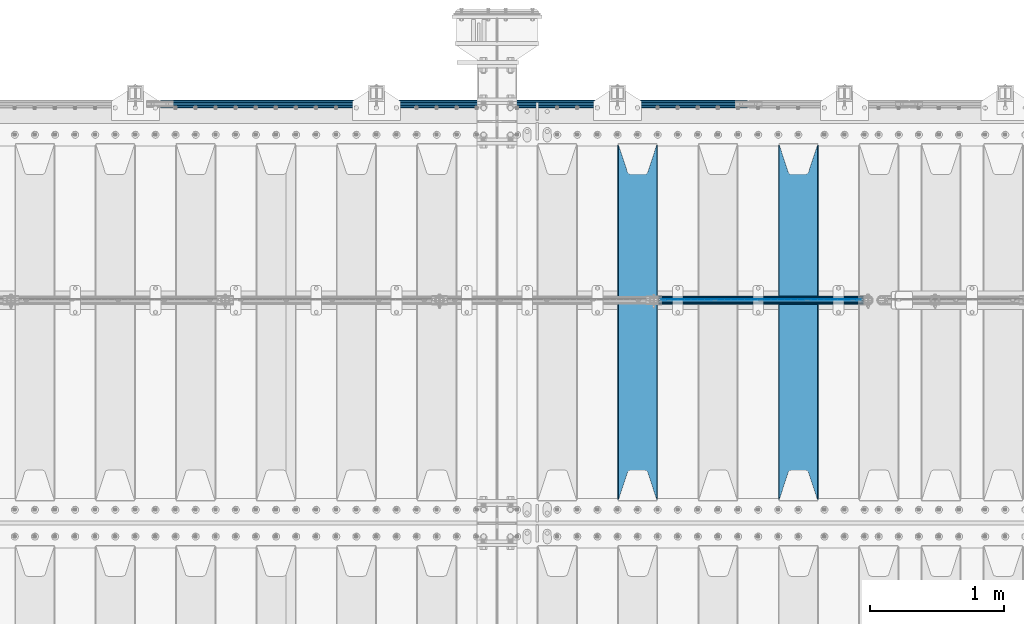
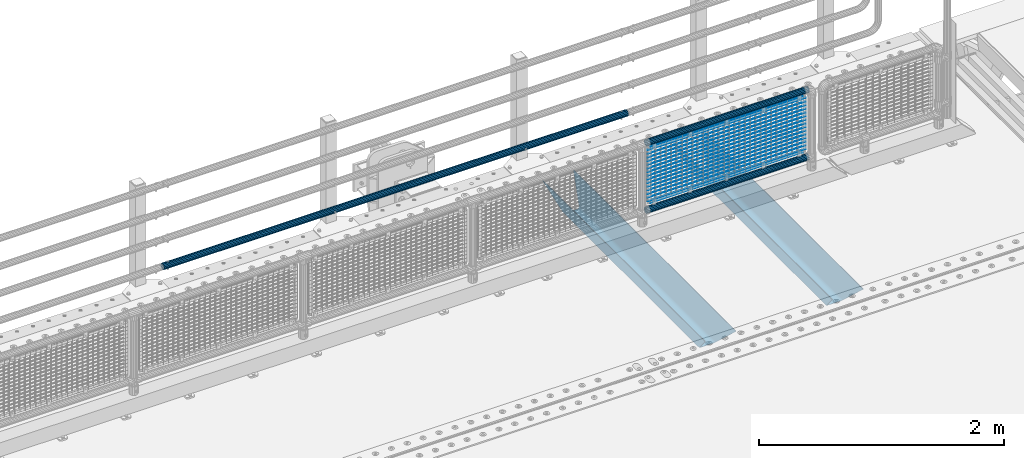
# One storey, part 107 of 208: 22 beams.
"""IFC2X3 building model written with IfcOpenShell, lengths in millimetres."""

from ifc_helpers import new_model, si_unit, frame, origin_with_axes, place, context, subcontext, project, spatial, faceted_brep, material, type_object, element, save


model = new_model("IFC2X3")

# Units and contexts
model_context = context("Model", 3, precision=1e-05, world=origin_with_axes())
body_context = subcontext(model_context, "Body", "Model", "MODEL_VIEW")
ifc_project = project(units=[si_unit("LENGTHUNIT", "METRE", prefix="MILLI"), si_unit("AREAUNIT", "SQUARE_METRE"), si_unit("VOLUMEUNIT", "CUBIC_METRE"), si_unit("MASSUNIT", "GRAM", prefix="KILO"), si_unit("TIMEUNIT", "SECOND"), si_unit("PLANEANGLEUNIT", "RADIAN"), si_unit("SOLIDANGLEUNIT", "STERADIAN"), si_unit("THERMODYNAMICTEMPERATUREUNIT", "DEGREE_CELSIUS"), si_unit("LUMINOUSINTENSITYUNIT", "LUMEN")], contexts=[model_context])

# Site, building, storey
site_placement = place(None, origin_with_axes())
site = spatial("IfcSite", under=ifc_project, at=site_placement, CompositionType="ELEMENT")
building_placement = place(site_placement, origin_with_axes())
building = spatial("IfcBuilding", under=site, at=building_placement, Name="Standard", CompositionType="ELEMENT")
storey_placement = place(building_placement, origin_with_axes())
storey = spatial("IfcBuildingStorey", under=building, at=storey_placement, Name="Undefined", CompositionType="ELEMENT", Elevation=0.0)

# Beams
ifc_material_1 = material(Name="STEEL/S355N")
beam_type_1 = type_object("IfcBeamType", PredefinedType="NOTDEFINED")
beam_1_placement = place(storey_placement, frame((-27950.0, 3175.0, -115.0), z_axis=(0.0, 0.0, 1.0), x_axis=(0.0, 1.0, 0.0)))
element("IfcBeam", 1, at=beam_1_placement, inside=storey, type_object=beam_type_1, material=ifc_material_1, context=body_context, shape_type="Brep", body=[
    faceted_brep([(0.0, 150.0, 115.0), (0.0, 143.689999999999, 115.0), (2650.00000000297, 143.689999999999, 115.0), (2650.00000000297, 150.0, 115.0), (2650.00000000297, 142.059565218402, 110.0000000031), (2650.00000000297, 148.369565218403, 110.0000000031), (2441.90079219208, -80.1103600731112, -98.0992078077845), (2437.7588105432, -77.5672621345584, -102.241189456673), (2434.06523489746, -74.4080125315522, -105.934765102404), (2430.91086095089, -70.710272125576, -109.089139048974), (2428.37322971128, -66.5649389910068, -111.626770288588), (2426.51472138055, -62.0739139532889, -113.485278619323), (2425.38102192091, -57.3475956567672, -114.618978078955), (2424.99999999987, -52.5021667386536, -115.0), (2424.99999999987, 52.5021667386536, -115.0), (2425.38102192091, 57.3475956567672, -114.618978078955), (2426.51472138055, 62.0739139532889, -113.485278619323), (2428.37322971128, 66.5649389910068, -111.626770288588), (2430.91086095089, 70.710272125576, -109.089139048974), (2434.06523489746, 74.4080125315522, -105.934765102404), (2437.7588105432, 77.5672621345584, -102.241189456673), (2441.90079219208, 80.1103600731112, -98.0992078077846), (2446.38936140511, 81.9747917625791, -93.6106385947584), (2448.24948500409, 76.2713538057251, -91.7505149957729), (2444.62967112262, 74.76777986261, -95.3703288772456), (2441.28936334126, 72.7168944282894, -98.710636658607), (2438.31067330438, 70.1691124903846, -101.689326695487), (2435.76682334747, 67.1870637758839, -104.233176652398), (2433.72034654133, 63.8440531834895, -106.279653458539), (2432.22154950041, 60.222258798236, -107.778450499454), (2431.30727574265, 56.4107117849089, -108.692724257221), (2430.99999999987, 52.5031078186876, -109.0), (2430.99999999987, -52.5031078186876, -109.0), (2431.30727574265, -56.4107117849089, -108.692724257221), (2432.22154950041, -60.222258798236, -107.778450499454), (2433.72034654133, -63.8440531834895, -106.279653458539), (2435.76682334747, -67.1870637758839, -104.233176652398), (2438.31067330438, -70.1691124903846, -101.689326695487), (2441.28936334126, -72.7168944282894, -98.7106366586071), (2444.62967112262, -74.76777986261, -95.3703288772457), (2448.24948500409, -76.2713538057251, -91.7505149957729), (2650.00000000297, -142.059565218402, 110.0000000031), (2650.00000000297, -148.369565218403, 110.0000000031), (2446.38936140511, -81.9747917625791, -93.6106385947584), (2650.00000000297, -143.689999999999, 115.0), (2650.00000000297, -150.0, 115.0), (0.0, -143.689999999999, 115.0), (0.0, -150.0, 115.0), (0.0, -148.369565218261, 110.000000002663), (203.610638597421, -81.9747917625791, -93.6106385947584), (208.099207810448, -80.1103600731112, -98.0992078077845), (212.241189459336, -77.5672621345584, -102.241189456673), (215.934765105067, -74.4080125315522, -105.934765102404), (219.089139051637, -70.710272125576, -109.089139048974), (221.626770291251, -66.5649389910068, -111.626770288588), (223.485278621986, -62.0739139532889, -113.485278619323), (224.618978081618, -57.3475956567672, -114.618978078955), (225.000000002663, -52.5021667386536, -115.0), (225.000000002663, 52.5021667386536, -115.0), (224.618978081618, 57.3475956567672, -114.618978078955), (223.485278621986, 62.0739139532889, -113.485278619323), (221.626770291251, 66.5649389910068, -111.626770288588), (219.089139051637, 70.710272125576, -109.089139048974), (215.934765105067, 74.4080125315522, -105.934765102404), (212.241189459336, 77.5672621345584, -102.241189456673), (208.099207810448, 80.1103600731112, -98.0992078077846), (203.610638597421, 81.9747917625791, -93.6106385947584), (0.0, 148.369565218261, 110.000000002663), (0.0, 142.05956521826, 110.000000002663), (201.750514998436, 76.2713538057251, -91.7505149957729), (205.370328879908, 74.76777986261, -95.3703288772456), (208.71063666127, 72.7168944282894, -98.710636658607), (211.68932669815, 70.1691124903846, -101.689326695487), (214.233176655061, 67.1870637758839, -104.233176652398), (216.279653461202, 63.8440531834895, -106.279653458539), (217.778450502116, 60.222258798236, -107.778450499454), (218.692724259884, 56.4107117849089, -108.692724257221), (219.000000002663, 52.5031078186876, -109.0), (219.000000002663, -52.5031078186876, -109.0), (218.692724259884, -56.4107117849089, -108.692724257221), (217.778450502116, -60.222258798236, -107.778450499454), (216.279653461202, -63.8440531834895, -106.279653458539), (214.233176655061, -67.1870637758839, -104.233176652398), (211.68932669815, -70.1691124903846, -101.689326695487), (208.71063666127, -72.7168944282894, -98.7106366586071), (205.370328879908, -74.76777986261, -95.3703288772457), (201.750514998436, -76.2713538057251, -91.7505149957729), (0.0, -142.05956521826, 110.000000002663)], [[[0, 1, 2, 3]], [[3, 2, 4, 5]], [[6, 7, 8, 9, 10, 11, 12, 13, 14, 15, 16, 17, 18, 19, 20, 21, 22, 5, 4, 23, 24, 25, 26, 27, 28, 29, 30, 31, 32, 33, 34, 35, 36, 37, 38, 39, 40, 41, 42, 43]], [[44, 45, 42, 41]], [[46, 47, 45, 44]], [[43, 42, 45, 47, 48, 49]], [[6, 43, 49, 50]], [[7, 6, 50, 51]], [[8, 7, 51, 52]], [[9, 8, 52, 53]], [[10, 9, 53, 54]], [[11, 10, 54, 55]], [[12, 11, 55, 56]], [[13, 12, 56, 57]], [[14, 13, 57, 58]], [[15, 14, 58, 59]], [[16, 15, 59, 60]], [[17, 16, 60, 61]], [[18, 17, 61, 62]], [[19, 18, 62, 63]], [[20, 19, 63, 64]], [[21, 20, 64, 65]], [[22, 21, 65, 66]], [[0, 3, 5, 22, 66, 67]], [[1, 0, 67, 68]], [[23, 4, 2, 1, 68, 69]], [[24, 23, 69, 70]], [[25, 24, 70, 71]], [[26, 25, 71, 72]], [[27, 26, 72, 73]], [[28, 27, 73, 74]], [[29, 28, 74, 75]], [[30, 29, 75, 76]], [[31, 30, 76, 77]], [[32, 31, 77, 78]], [[33, 32, 78, 79]], [[34, 33, 79, 80]], [[35, 34, 80, 81]], [[36, 35, 81, 82]], [[37, 36, 82, 83]], [[38, 37, 83, 84]], [[39, 38, 84, 85]], [[40, 39, 85, 86]], [[46, 44, 41, 40, 86, 87]], [[47, 46, 87, 48]], [[86, 85, 84, 83, 82, 81, 80, 79, 78, 77, 76, 75, 74, 73, 72, 71, 70, 69, 68, 67, 66, 65, 64, 63, 62, 61, 60, 59, 58, 57, 56, 55, 54, 53, 52, 51, 50, 49, 48, 87]]]),
])
beam_2_placement = place(storey_placement, frame((-29150.0, 3175.0, -115.0), z_axis=(0.0, 0.0, 1.0), x_axis=(0.0, 1.0, 0.0)))
element("IfcBeam", 2, at=beam_2_placement, inside=storey, type_object=beam_type_1, material=ifc_material_1, context=body_context, shape_type="Brep", body=[
    faceted_brep([(0.0, 150.0, 115.0), (0.0, 143.689999999999, 115.0), (2650.00000000297, 143.689999999999, 115.0), (2650.00000000297, 150.0, 115.0), (2650.00000000297, 142.059565218402, 110.0000000031), (2650.00000000297, 148.369565218403, 110.0000000031), (2441.90079219208, -80.1103600731112, -98.0992078077845), (2437.7588105432, -77.5672621345584, -102.241189456673), (2434.06523489746, -74.4080125315522, -105.934765102404), (2430.91086095089, -70.710272125576, -109.089139048974), (2428.37322971128, -66.5649389910068, -111.626770288588), (2426.51472138055, -62.0739139532889, -113.485278619323), (2425.38102192091, -57.3475956567672, -114.618978078955), (2424.99999999987, -52.5021667386536, -115.0), (2424.99999999987, 52.5021667386536, -115.0), (2425.38102192091, 57.3475956567672, -114.618978078955), (2426.51472138055, 62.0739139532889, -113.485278619323), (2428.37322971128, 66.5649389910068, -111.626770288588), (2430.91086095089, 70.710272125576, -109.089139048974), (2434.06523489746, 74.4080125315522, -105.934765102404), (2437.7588105432, 77.5672621345584, -102.241189456673), (2441.90079219208, 80.1103600731112, -98.0992078077846), (2446.38936140511, 81.9747917625791, -93.6106385947584), (2448.24948500409, 76.2713538057251, -91.7505149957729), (2444.62967112262, 74.76777986261, -95.3703288772456), (2441.28936334126, 72.7168944282894, -98.710636658607), (2438.31067330438, 70.1691124903846, -101.689326695487), (2435.76682334747, 67.1870637758839, -104.233176652398), (2433.72034654133, 63.8440531834895, -106.279653458539), (2432.22154950041, 60.222258798236, -107.778450499454), (2431.30727574265, 56.4107117849089, -108.692724257221), (2430.99999999987, 52.5031078186876, -109.0), (2430.99999999987, -52.5031078186876, -109.0), (2431.30727574265, -56.4107117849089, -108.692724257221), (2432.22154950041, -60.222258798236, -107.778450499454), (2433.72034654133, -63.8440531834895, -106.279653458539), (2435.76682334747, -67.1870637758839, -104.233176652398), (2438.31067330438, -70.1691124903846, -101.689326695487), (2441.28936334126, -72.7168944282894, -98.7106366586071), (2444.62967112262, -74.76777986261, -95.3703288772457), (2448.24948500409, -76.2713538057251, -91.7505149957729), (2650.00000000297, -142.059565218402, 110.0000000031), (2650.00000000297, -148.369565218403, 110.0000000031), (2446.38936140511, -81.9747917625791, -93.6106385947584), (2650.00000000297, -143.689999999999, 115.0), (2650.00000000297, -150.0, 115.0), (0.0, -143.689999999999, 115.0), (0.0, -150.0, 115.0), (0.0, -148.369565218261, 110.000000002663), (203.610638597421, -81.9747917625791, -93.6106385947584), (208.099207810448, -80.1103600731112, -98.0992078077845), (212.241189459336, -77.5672621345584, -102.241189456673), (215.934765105067, -74.4080125315522, -105.934765102404), (219.089139051637, -70.710272125576, -109.089139048974), (221.626770291251, -66.5649389910068, -111.626770288588), (223.485278621986, -62.0739139532889, -113.485278619323), (224.618978081618, -57.3475956567672, -114.618978078955), (225.000000002663, -52.5021667386536, -115.0), (225.000000002663, 52.5021667386536, -115.0), (224.618978081618, 57.3475956567672, -114.618978078955), (223.485278621986, 62.0739139532889, -113.485278619323), (221.626770291251, 66.5649389910068, -111.626770288588), (219.089139051637, 70.710272125576, -109.089139048974), (215.934765105067, 74.4080125315522, -105.934765102404), (212.241189459336, 77.5672621345584, -102.241189456673), (208.099207810448, 80.1103600731112, -98.0992078077846), (203.610638597421, 81.9747917625791, -93.6106385947584), (0.0, 148.369565218261, 110.000000002663), (0.0, 142.05956521826, 110.000000002663), (201.750514998436, 76.2713538057251, -91.7505149957729), (205.370328879908, 74.76777986261, -95.3703288772456), (208.71063666127, 72.7168944282894, -98.710636658607), (211.68932669815, 70.1691124903846, -101.689326695487), (214.233176655061, 67.1870637758839, -104.233176652398), (216.279653461202, 63.8440531834895, -106.279653458539), (217.778450502116, 60.222258798236, -107.778450499454), (218.692724259884, 56.4107117849089, -108.692724257221), (219.000000002663, 52.5031078186876, -109.0), (219.000000002663, -52.5031078186876, -109.0), (218.692724259884, -56.4107117849089, -108.692724257221), (217.778450502116, -60.222258798236, -107.778450499454), (216.279653461202, -63.8440531834895, -106.279653458539), (214.233176655061, -67.1870637758839, -104.233176652398), (211.68932669815, -70.1691124903846, -101.689326695487), (208.71063666127, -72.7168944282894, -98.7106366586071), (205.370328879908, -74.76777986261, -95.3703288772457), (201.750514998436, -76.2713538057251, -91.7505149957729), (0.0, -142.05956521826, 110.000000002663)], [[[0, 1, 2, 3]], [[3, 2, 4, 5]], [[6, 7, 8, 9, 10, 11, 12, 13, 14, 15, 16, 17, 18, 19, 20, 21, 22, 5, 4, 23, 24, 25, 26, 27, 28, 29, 30, 31, 32, 33, 34, 35, 36, 37, 38, 39, 40, 41, 42, 43]], [[44, 45, 42, 41]], [[46, 47, 45, 44]], [[43, 42, 45, 47, 48, 49]], [[6, 43, 49, 50]], [[7, 6, 50, 51]], [[8, 7, 51, 52]], [[9, 8, 52, 53]], [[10, 9, 53, 54]], [[11, 10, 54, 55]], [[12, 11, 55, 56]], [[13, 12, 56, 57]], [[14, 13, 57, 58]], [[15, 14, 58, 59]], [[16, 15, 59, 60]], [[17, 16, 60, 61]], [[18, 17, 61, 62]], [[19, 18, 62, 63]], [[20, 19, 63, 64]], [[21, 20, 64, 65]], [[22, 21, 65, 66]], [[0, 3, 5, 22, 66, 67]], [[1, 0, 67, 68]], [[23, 4, 2, 1, 68, 69]], [[24, 23, 69, 70]], [[25, 24, 70, 71]], [[26, 25, 71, 72]], [[27, 26, 72, 73]], [[28, 27, 73, 74]], [[29, 28, 74, 75]], [[30, 29, 75, 76]], [[31, 30, 76, 77]], [[32, 31, 77, 78]], [[33, 32, 78, 79]], [[34, 33, 79, 80]], [[35, 34, 80, 81]], [[36, 35, 81, 82]], [[37, 36, 82, 83]], [[38, 37, 83, 84]], [[39, 38, 84, 85]], [[40, 39, 85, 86]], [[46, 44, 41, 40, 86, 87]], [[47, 46, 87, 48]], [[86, 85, 84, 83, 82, 81, 80, 79, 78, 77, 76, 75, 74, 73, 72, 71, 70, 69, 68, 67, 66, 65, 64, 63, 62, 61, 60, 59, 58, 57, 56, 55, 54, 53, 52, 51, 50, 49, 48, 87]]]),
])
ifc_material_2 = material(Name="Misc_Undefined")
beam_type_2 = type_object("IfcBeamType", Name="D3", PredefinedType="NOTDEFINED")
for number, where, z_axis, x_axis in (
    (3, (-28974.0, 4670.50000000001, 851.597000000006), (0.0, 0.0, 1.0), (1.0, 0.0, 0.0)),
    (4, (-28974.0, 4670.50000000001, 669.452000000006), (0.0, 0.0, 1.0), (1.0, 0.0, 0.0)),
    (5, (-28974.0, 4670.50000000001, 523.736000000006), (0.0, 0.0, 1.0), (1.0, 0.0, 0.0)),
    (6, (-28974.0, 4670.50000000001, 487.307000000006), (0.0, 0.0, 1.0), (1.0, 0.0, 0.0)),
    (7, (-28974.0, 4670.50000000001, 705.881000000006), (0.0, 0.0, 1.0), (1.0, 0.0, 0.0)),
    (8, (-28974.0, 4670.50000000001, 596.594000000006), (0.0, 0.0, 1.0), (1.0, 0.0, 0.0)),
    (9, (-28974.0, 4670.50000000001, 450.878000000006), (0.0, 0.0, 1.0), (1.0, 0.0, 0.0)),
    (10, (-28974.0, 4670.50000000001, 815.168000000006), (0.0, 0.0, 1.0), (1.0, 0.0, 0.0)),
    (11, (-28974.0, 4670.50000000001, 888.026000000006), (0.0, 0.0, 1.0), (1.0, 0.0, 0.0)),
    (12, (-28974.0, 4670.50000000001, 778.739000000006), (0.0, 0.0, 1.0), (1.0, 0.0, 0.0)),
    (13, (-28974.0, 4670.50000000001, 742.310000000006), (0.0, 0.0, 1.0), (1.0, 0.0, 0.0)),
    (14, (-28974.0, 4670.50000000001, 633.023000000006), (0.0, 0.0, 1.0), (1.0, 0.0, 0.0)),
    (15, (-28974.0, 4670.50000000001, 560.165000000006), (0.0, 0.0, 1.0), (1.0, 0.0, 0.0)),
    (16, (-28974.0, 4670.50000000001, 414.449000000006), (0.0, 0.0, 1.0), (1.0, 0.0, 0.0)),
):
    element("IfcBeam", number, at=place(storey_placement, frame(where, z_axis=z_axis, x_axis=x_axis)), inside=storey, type_object=beam_type_2, material=ifc_material_2, ObjectType="D3", context=body_context, shape_type="Brep", body=[
        faceted_brep([(0.0, -1.49999999999909, 3.63797880709171e-12), (-7.27595761418343e-12, -0.749999999999091, -1.29903810567669), (1490.0, -0.75, -1.29903810567669), (1490.0, -1.5, 0.0), (-3.63797880709171e-12, 0.750000000000909, -1.29903810567669), (1490.0, 0.75, -1.29903810567669), (0.0, 1.50000000000182, 3.63797880709171e-12), (1490.0, 1.5, 0.0), (-3.63797880709171e-12, 0.750000000000909, 1.29903810567669), (1490.0, 0.75, 1.29903810567669), (-7.27595761418343e-12, -0.749999999999091, 1.29903810567669), (1490.0, -0.75, 1.29903810567669)], [[[0, 1, 2, 3]], [[1, 4, 5, 2]], [[4, 6, 7, 5]], [[6, 8, 9, 7]], [[8, 10, 11, 9]], [[10, 0, 3, 11]], [[5, 7, 9, 11, 3, 2]], [[10, 8, 6, 4, 1, 0]]]),
    ])
beam_3_placement = place(storey_placement, frame((-28949.0, 4670.50000000001, 353.020000000006), z_axis=(0.0, 0.0, 1.0), x_axis=(1.0, 0.0, 0.0)))
element("IfcBeam", 17, at=beam_3_placement, inside=storey, type_object=beam_type_2, material=ifc_material_2, ObjectType="D3", context=body_context, shape_type="Brep", body=[
    faceted_brep([(0.0, -1.49999999999909, 3.63797880709171e-12), (-7.27595761418343e-12, -0.749999999999091, -1.29903810567669), (1440.0, -0.75, -1.29903810567669), (1440.0, -1.5, 0.0), (-3.63797880709171e-12, 0.750000000000909, -1.29903810567669), (1440.0, 0.75, -1.29903810567663), (0.0, 1.50000000000182, 3.63797880709171e-12), (1440.0, 1.5, 0.0), (-3.63797880709171e-12, 0.750000000000909, 1.29903810567669), (1440.0, 0.75, 1.29903810567669), (-7.27595761418343e-12, -0.749999999999091, 1.29903810567669), (1440.0, -0.75, 1.29903810567669)], [[[0, 1, 2, 3]], [[1, 4, 5, 2]], [[4, 6, 7, 5]], [[6, 8, 9, 7]], [[8, 10, 11, 9]], [[10, 0, 3, 11]], [[5, 7, 9, 11, 3, 2]], [[10, 8, 6, 4, 1, 0]]]),
])
beam_4_placement = place(storey_placement, frame((-28974.0, 4670.50000000001, 378.020000000006), z_axis=(0.0, 0.0, 1.0), x_axis=(1.0, 0.0, 0.0)))
element("IfcBeam", 18, at=beam_4_placement, inside=storey, type_object=beam_type_2, material=ifc_material_2, ObjectType="D3", context=body_context, shape_type="Brep", body=[
    faceted_brep([(0.0, -1.49999999999909, 3.63797880709171e-12), (-7.27595761418343e-12, -0.749999999999091, -1.29903810567669), (1490.0, -0.75, -1.29903810567669), (1490.0, -1.5, 0.0), (-3.63797880709171e-12, 0.750000000000909, -1.29903810567669), (1490.0, 0.75, -1.29903810567669), (0.0, 1.50000000000182, 3.63797880709171e-12), (1490.0, 1.5, 0.0), (-3.63797880709171e-12, 0.750000000000909, 1.29903810567669), (1490.0, 0.75, 1.29903810567669), (-7.27595761418343e-12, -0.749999999999091, 1.29903810567669), (1490.0, -0.75, 1.29903810567669)], [[[0, 1, 2, 3]], [[1, 4, 5, 2]], [[4, 6, 7, 5]], [[6, 8, 9, 7]], [[8, 10, 11, 9]], [[10, 0, 3, 11]], [[5, 7, 9, 11, 3, 2]], [[10, 8, 6, 4, 1, 0]]]),
])
beam_5_placement = place(storey_placement, frame((-28949.0, 4670.50000000001, 913.020000000006), z_axis=(0.0, 0.0, 1.0), x_axis=(1.0, 0.0, 0.0)))
element("IfcBeam", 19, at=beam_5_placement, inside=storey, type_object=beam_type_2, material=ifc_material_2, ObjectType="D3", context=body_context, shape_type="Brep", body=[
    faceted_brep([(0.0, -1.49999999999909, 3.63797880709171e-12), (-7.27595761418343e-12, -0.749999999999091, -1.29903810567669), (1440.0, -0.75, -1.29903810567669), (1440.0, -1.5, 0.0), (-3.63797880709171e-12, 0.750000000000909, -1.29903810567669), (1440.0, 0.75, -1.29903810567663), (0.0, 1.50000000000182, 3.63797880709171e-12), (1440.0, 1.5, 0.0), (-3.63797880709171e-12, 0.750000000000909, 1.29903810567669), (1440.0, 0.75, 1.29903810567669), (-7.27595761418343e-12, -0.749999999999091, 1.29903810567669), (1440.0, -0.75, 1.29903810567669)], [[[0, 1, 2, 3]], [[1, 4, 5, 2]], [[4, 6, 7, 5]], [[6, 8, 9, 7]], [[8, 10, 11, 9]], [[10, 0, 3, 11]], [[5, 7, 9, 11, 3, 2]], [[10, 8, 6, 4, 1, 0]]]),
])
ifc_material_3 = material()
beam_type_3 = type_object("IfcBeamType", PredefinedType="NOTDEFINED")
beam_6_placement = place(storey_placement, frame((-28994.15, 4664.50000000001, 298.170000000007), z_axis=(0.0, 0.0, 1.0), x_axis=(1.0, 0.0, 0.0)))
element("IfcBeam", 20, at=beam_6_placement, inside=storey, type_object=beam_type_3, material=ifc_material_3, context=body_context, shape_type="Brep", body=[
    faceted_brep([(0.0, -25.3500000000004, 0.0), (0.0, -23.4203461491616, 9.70102501045403), (1530.0, -23.4203461491616, 9.70102501045506), (1530.0, -25.3500000000004, 0.0), (0.0, -17.9251569030794, 17.9251569030785), (1530.0, -17.9251569030794, 17.925156903079), (0.0, -9.70102501045494, 23.4203461491597), (1530.0, -9.70102501045494, 23.4203461491611), (0.0, 0.0, 25.3499999999985), (1530.0, 0.0, 25.35), (0.0, 9.70102501045494, 23.4203461491597), (1530.0, 9.70102501045494, 23.4203461491611), (0.0, 17.9251569030794, 17.9251569030785), (1530.0, 17.9251569030794, 17.925156903079), (0.0, 23.4203461491616, 9.70102501045403), (1530.0, 23.4203461491616, 9.701025010455), (0.0, 25.3500000000004, 0.0), (1530.0, 25.3500000000004, 0.0), (0.0, 23.4203461491616, -9.70102501045403), (1530.0, 23.4203461491616, -9.70102501045506), (0.0, 17.9251569030794, -17.9251569030785), (1530.0, 17.9251569030794, -17.925156903079), (0.0, 9.70102501045494, -23.4203461491597), (1530.0, 9.70102501045494, -23.4203461491611), (0.0, 0.0, -25.3499999999985), (1530.0, 0.0, -25.35), (0.0, -9.70102501045494, -23.4203461491597), (1530.0, -9.70102501045494, -23.4203461491611), (0.0, -17.9251569030794, -17.9251569030785), (1530.0, -17.9251569030794, -17.925156903079), (0.0, -23.4203461491616, -9.70102501045403), (1530.0, -23.4203461491616, -9.701025010455), (0.0, -30.1499999999996, 0.0), (0.0, -27.8549679052148, -11.5379054858058), (1530.0, -27.8549679052148, -11.5379054858075), (1530.0, -30.1499999999996, 0.0), (0.0, -21.3192694527743, -21.3192694527752), (1530.0, -21.3192694527743, -21.3192694527744), (0.0, -11.5379054858076, -27.8549679052157), (1530.0, -11.5379054858076, -27.8549679052153), (0.0, 0.0, -30.1500000000015), (1530.0, 0.0, -30.15), (0.0, 11.5379054858076, -27.8549679052157), (1530.0, 11.5379054858076, -27.8549679052153), (0.0, 21.3192694527743, -21.3192694527752), (1530.0, 21.3192694527743, -21.3192694527744), (0.0, 27.8549679052157, -11.5379054858058), (1530.0, 27.8549679052157, -11.5379054858075), (0.0, 30.1499999999996, 0.0), (1530.0, 30.1499999999996, 0.0), (0.0, 27.8549679052157, 11.5379054858058), (1530.0, 27.8549679052157, 11.5379054858075), (0.0, 21.3192694527743, 21.3192694527752), (1530.0, 21.3192694527743, 21.3192694527744), (0.0, 11.5379054858076, 27.8549679052157), (1530.0, 11.5379054858076, 27.8549679052153), (0.0, 0.0, 30.1500000000015), (1530.0, 0.0, 30.15), (0.0, -11.5379054858076, 27.8549679052157), (1530.0, -11.5379054858076, 27.8549679052153), (0.0, -21.3192694527743, 21.3192694527752), (1530.0, -21.3192694527743, 21.3192694527744), (0.0, -27.8549679052157, 11.5379054858058), (1530.0, -27.8549679052157, 11.5379054858075)], [[[0, 1, 2, 3]], [[1, 4, 5, 2]], [[4, 6, 7, 5]], [[6, 8, 9, 7]], [[8, 10, 11, 9]], [[10, 12, 13, 11]], [[12, 14, 15, 13]], [[14, 16, 17, 15]], [[16, 18, 19, 17]], [[18, 20, 21, 19]], [[20, 22, 23, 21]], [[22, 24, 25, 23]], [[24, 26, 27, 25]], [[26, 28, 29, 27]], [[28, 30, 31, 29]], [[30, 0, 3, 31]], [[32, 33, 34, 35]], [[33, 36, 37, 34]], [[36, 38, 39, 37]], [[38, 40, 41, 39]], [[40, 42, 43, 41]], [[42, 44, 45, 43]], [[44, 46, 47, 45]], [[46, 48, 49, 47]], [[48, 50, 51, 49]], [[50, 52, 53, 51]], [[52, 54, 55, 53]], [[54, 56, 57, 55]], [[56, 58, 59, 57]], [[58, 60, 61, 59]], [[60, 62, 63, 61]], [[62, 32, 35, 63]], [[37, 39, 41, 43, 45, 47, 49, 51, 53, 55, 57, 59, 61, 63, 35, 34], [5, 7, 9, 11, 13, 15, 17, 19, 21, 23, 25, 27, 29, 31, 3, 2]], [[62, 60, 58, 56, 54, 52, 50, 48, 46, 44, 42, 40, 38, 36, 33, 32], [30, 28, 26, 24, 22, 20, 18, 16, 14, 12, 10, 8, 6, 4, 1, 0]]]),
])
beam_7_placement = place(storey_placement, frame((-28994.15, 4664.50000000001, 969.850000000006), z_axis=(0.0, 0.0, 1.0), x_axis=(1.0, 0.0, 0.0)))
element("IfcBeam", 21, at=beam_7_placement, inside=storey, type_object=beam_type_3, material=ifc_material_3, context=body_context, shape_type="Brep", body=[
    faceted_brep([(0.0, -25.3500000000004, 0.0), (0.0, -23.4203461491616, 9.70102501045403), (1530.0, -23.4203461491616, 9.70102501045506), (1530.0, -25.3500000000004, 0.0), (0.0, -17.9251569030794, 17.9251569030785), (1530.0, -17.9251569030794, 17.925156903079), (0.0, -9.70102501045494, 23.4203461491597), (1530.0, -9.70102501045494, 23.4203461491611), (0.0, 0.0, 25.3499999999985), (1530.0, 0.0, 25.35), (0.0, 9.70102501045494, 23.4203461491597), (1530.0, 9.70102501045494, 23.4203461491611), (0.0, 17.9251569030794, 17.9251569030785), (1530.0, 17.9251569030794, 17.925156903079), (0.0, 23.4203461491616, 9.70102501045403), (1530.0, 23.4203461491616, 9.701025010455), (0.0, 25.3500000000004, 0.0), (1530.0, 25.3500000000004, 0.0), (0.0, 23.4203461491616, -9.70102501045403), (1530.0, 23.4203461491616, -9.70102501045506), (0.0, 17.9251569030794, -17.9251569030785), (1530.0, 17.9251569030794, -17.925156903079), (0.0, 9.70102501045494, -23.4203461491597), (1530.0, 9.70102501045494, -23.4203461491611), (0.0, 0.0, -25.3499999999985), (1530.0, 0.0, -25.35), (0.0, -9.70102501045494, -23.4203461491597), (1530.0, -9.70102501045494, -23.4203461491611), (0.0, -17.9251569030794, -17.9251569030785), (1530.0, -17.9251569030794, -17.925156903079), (0.0, -23.4203461491616, -9.70102501045403), (1530.0, -23.4203461491616, -9.701025010455), (0.0, -30.1499999999996, 0.0), (0.0, -27.8549679052148, -11.5379054858058), (1530.0, -27.8549679052148, -11.5379054858075), (1530.0, -30.1499999999996, 0.0), (0.0, -21.3192694527743, -21.3192694527752), (1530.0, -21.3192694527743, -21.3192694527744), (0.0, -11.5379054858076, -27.8549679052157), (1530.0, -11.5379054858076, -27.8549679052153), (0.0, 0.0, -30.1500000000015), (1530.0, 0.0, -30.15), (0.0, 11.5379054858076, -27.8549679052157), (1530.0, 11.5379054858076, -27.8549679052153), (0.0, 21.3192694527743, -21.3192694527752), (1530.0, 21.3192694527743, -21.3192694527744), (0.0, 27.8549679052157, -11.5379054858058), (1530.0, 27.8549679052157, -11.5379054858075), (0.0, 30.1499999999996, 0.0), (1530.0, 30.1499999999996, 0.0), (0.0, 27.8549679052157, 11.5379054858058), (1530.0, 27.8549679052157, 11.5379054858075), (0.0, 21.3192694527743, 21.3192694527752), (1530.0, 21.3192694527743, 21.3192694527744), (0.0, 11.5379054858076, 27.8549679052157), (1530.0, 11.5379054858076, 27.8549679052153), (0.0, 0.0, 30.1500000000015), (1530.0, 0.0, 30.15), (0.0, -11.5379054858076, 27.8549679052157), (1530.0, -11.5379054858076, 27.8549679052153), (0.0, -21.3192694527743, 21.3192694527752), (1530.0, -21.3192694527743, 21.3192694527744), (0.0, -27.8549679052157, 11.5379054858058), (1530.0, -27.8549679052157, 11.5379054858075)], [[[0, 1, 2, 3]], [[1, 4, 5, 2]], [[4, 6, 7, 5]], [[6, 8, 9, 7]], [[8, 10, 11, 9]], [[10, 12, 13, 11]], [[12, 14, 15, 13]], [[14, 16, 17, 15]], [[16, 18, 19, 17]], [[18, 20, 21, 19]], [[20, 22, 23, 21]], [[22, 24, 25, 23]], [[24, 26, 27, 25]], [[26, 28, 29, 27]], [[28, 30, 31, 29]], [[30, 0, 3, 31]], [[32, 33, 34, 35]], [[33, 36, 37, 34]], [[36, 38, 39, 37]], [[38, 40, 41, 39]], [[40, 42, 43, 41]], [[42, 44, 45, 43]], [[44, 46, 47, 45]], [[46, 48, 49, 47]], [[48, 50, 51, 49]], [[50, 52, 53, 51]], [[52, 54, 55, 53]], [[54, 56, 57, 55]], [[56, 58, 59, 57]], [[58, 60, 61, 59]], [[60, 62, 63, 61]], [[62, 32, 35, 63]], [[37, 39, 41, 43, 45, 47, 49, 51, 53, 55, 57, 59, 61, 63, 35, 34], [5, 7, 9, 11, 13, 15, 17, 19, 21, 23, 25, 27, 29, 31, 3, 2]], [[62, 60, 58, 56, 54, 52, 50, 48, 46, 44, 42, 40, 38, 36, 33, 32], [30, 28, 26, 24, 22, 20, 18, 16, 14, 12, 10, 8, 6, 4, 1, 0]]]),
])
beam_type_4 = type_object("IfcBeamType", PredefinedType="NOTDEFINED")
beam_8_placement = place(storey_placement, frame((-28328.0000000001, 6129.85000000019, 149.849999999725), z_axis=(0.0, 0.0, -1.0), x_axis=(-1.0, 0.0, 0.0)))
element("IfcBeam", 22, at=beam_8_placement, inside=storey, type_object=beam_type_4, material=ifc_material_3, context=body_context, shape_type="Brep", body=[
    faceted_brep([(0.0, -26.5500000000002, 0.0), (0.0, -24.5290015881747, 10.1602451292931), (4384.0, -24.5290015881747, 10.1602451292931), (4384.0, -26.5500000000002, 0.0), (0.0, -18.7736850405026, 18.7736850405028), (4384.0, -18.7736850405026, 18.7736850405028), (0.0, -10.1602451292929, 24.5290015881747), (4384.0, -10.1602451292929, 24.5290015881747), (0.0, 0.0, 26.55), (4384.0, 0.0, 26.55), (0.0, 10.1602451292929, 24.5290015881747), (4384.0, 10.1602451292929, 24.5290015881747), (0.0, 18.7736850405026, 18.7736850405028), (4384.0, 18.7736850405026, 18.7736850405028), (0.0, 24.5290015881747, 10.1602451292931), (4384.0, 24.5290015881747, 10.1602451292931), (0.0, 26.5500000000002, 0.0), (4384.0, 26.5500000000002, 0.0), (0.0, 24.5290015881747, -10.1602451292931), (4384.0, 24.5290015881747, -10.1602451292931), (0.0, 18.7736850405026, -18.7736850405028), (4384.0, 18.7736850405026, -18.7736850405028), (0.0, 10.1602451292929, -24.5290015881747), (4384.0, 10.1602451292929, -24.5290015881747), (0.0, 0.0, -26.55), (4384.0, 0.0, -26.55), (0.0, -10.1602451292929, -24.5290015881747), (4384.0, -10.1602451292929, -24.5290015881747), (0.0, -18.7736850405026, -18.7736850405028), (4384.0, -18.7736850405026, -18.7736850405028), (0.0, -24.5290015881747, -10.1602451292931), (4384.0, -24.5290015881747, -10.1602451292931), (0.0, -30.1499999999996, 0.0), (0.0, -27.8549679052148, -11.5379054858058), (4384.0, -27.8549679052148, -11.5379054858075), (4384.0, -30.1499999999996, 0.0), (0.0, -21.3192694527743, -21.3192694527752), (4384.0, -21.3192694527743, -21.3192694527744), (0.0, -11.5379054858076, -27.8549679052157), (4384.0, -11.5379054858076, -27.8549679052153), (0.0, 0.0, -30.1500000000015), (4384.0, 0.0, -30.15), (0.0, 11.5379054858076, -27.8549679052157), (4384.0, 11.5379054858076, -27.8549679052153), (0.0, 21.3192694527743, -21.3192694527752), (4384.0, 21.3192694527743, -21.3192694527744), (0.0, 27.8549679052157, -11.5379054858058), (4384.0, 27.8549679052157, -11.5379054858074), (0.0, 30.1499999999996, 0.0), (4384.0, 30.1499999999996, 0.0), (0.0, 27.8549679052157, 11.5379054858058), (4384.0, 27.8549679052157, 11.5379054858075), (0.0, 21.3192694527743, 21.3192694527752), (4384.0, 21.3192694527743, 21.3192694527744), (0.0, 11.5379054858076, 27.8549679052157), (4384.0, 11.5379054858076, 27.8549679052153), (0.0, 0.0, 30.1500000000015), (4384.0, 0.0, 30.15), (0.0, -11.5379054858076, 27.8549679052157), (4384.0, -11.5379054858076, 27.8549679052153), (0.0, -21.3192694527743, 21.3192694527752), (4384.0, -21.3192694527743, 21.3192694527744), (0.0, -27.8549679052157, 11.5379054858058), (4384.0, -27.8549679052157, 11.5379054858075)], [[[0, 1, 2, 3]], [[1, 4, 5, 2]], [[4, 6, 7, 5]], [[6, 8, 9, 7]], [[8, 10, 11, 9]], [[10, 12, 13, 11]], [[12, 14, 15, 13]], [[14, 16, 17, 15]], [[16, 18, 19, 17]], [[18, 20, 21, 19]], [[20, 22, 23, 21]], [[22, 24, 25, 23]], [[24, 26, 27, 25]], [[26, 28, 29, 27]], [[28, 30, 31, 29]], [[30, 0, 3, 31]], [[32, 33, 34, 35]], [[33, 36, 37, 34]], [[36, 38, 39, 37]], [[38, 40, 41, 39]], [[40, 42, 43, 41]], [[42, 44, 45, 43]], [[44, 46, 47, 45]], [[46, 48, 49, 47]], [[48, 50, 51, 49]], [[50, 52, 53, 51]], [[52, 54, 55, 53]], [[54, 56, 57, 55]], [[56, 58, 59, 57]], [[58, 60, 61, 59]], [[60, 62, 63, 61]], [[62, 32, 35, 63]], [[37, 39, 41, 43, 45, 47, 49, 51, 53, 55, 57, 59, 61, 63, 35, 34], [5, 7, 9, 11, 13, 15, 17, 19, 21, 23, 25, 27, 29, 31, 3, 2]], [[62, 60, 58, 56, 54, 52, 50, 48, 46, 44, 42, 40, 38, 36, 33, 32], [30, 28, 26, 24, 22, 20, 18, 16, 14, 12, 10, 8, 6, 4, 1, 0]]]),
])

save(model, "model.ifc")
